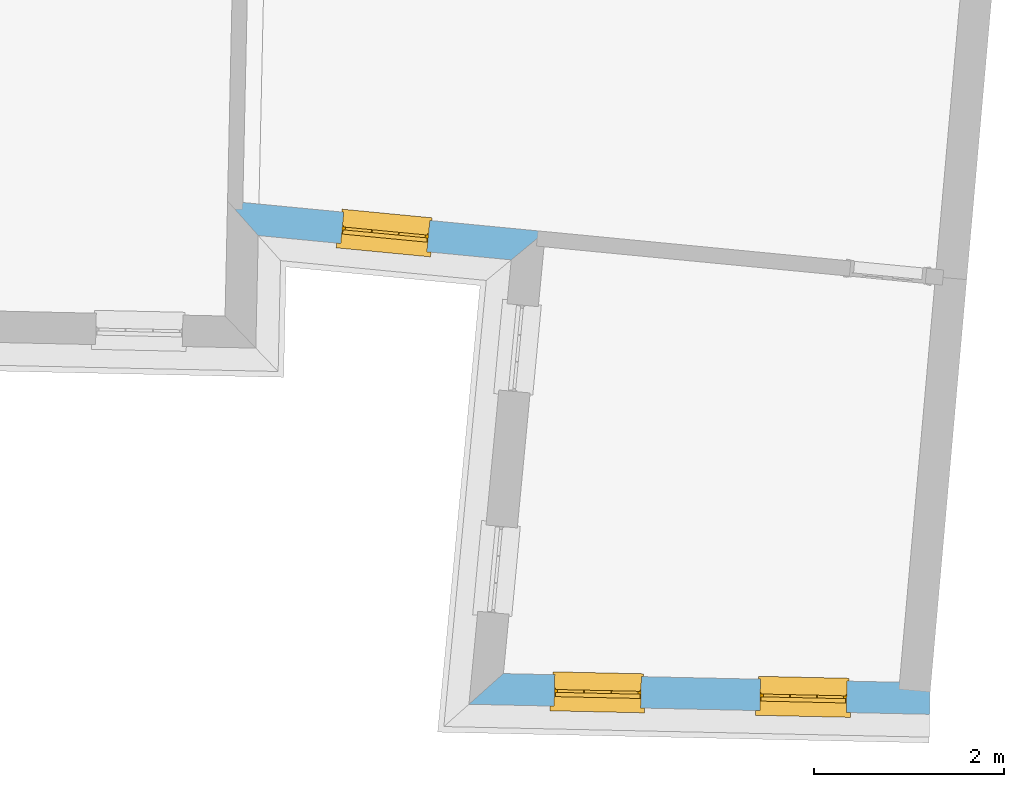
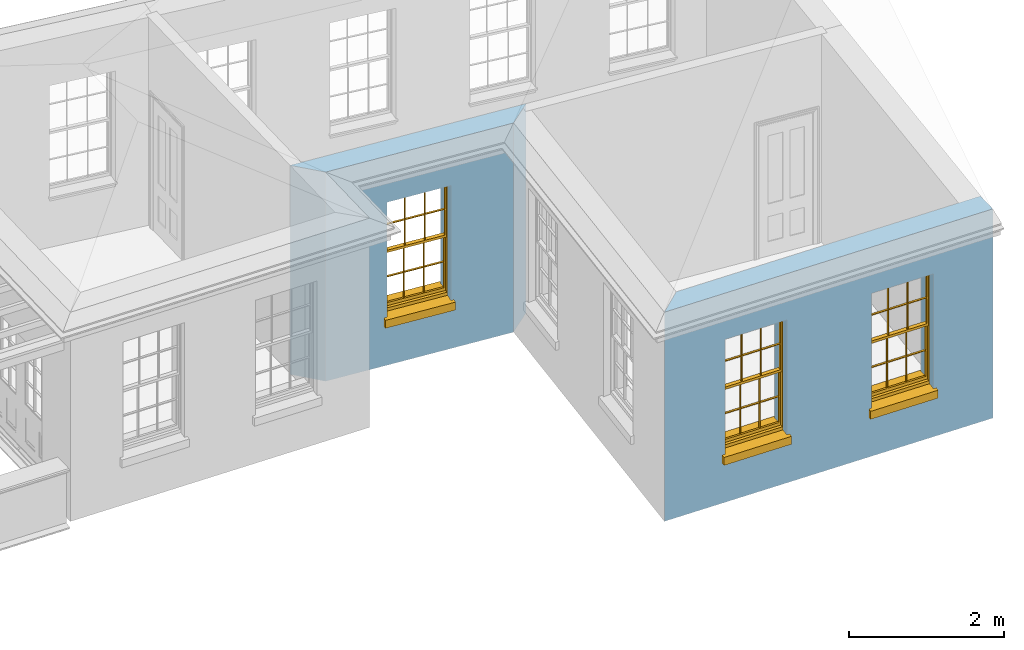
# One storey, part 6 of 12: 3 windows, 3 openings, plus 2 elements that do not belong to this part.
"""IFC2X3 building model written with IfcOpenShell, lengths in metres."""

from ifc_helpers import new_model, si_unit, frame, origin, place, context, subcontext, project, spatial, polyline, outline, extrude, faceted_brep, material, layer, layer_set, layer_usage, element, fill, save


model = new_model("IFC2X3")

# Units and contexts
model_context = context("Model", 3, world=origin())
body_context = subcontext(model_context, "Body", "Model", "MODEL_VIEW")
ifc_project = project(units=[si_unit("PLANEANGLEUNIT", "RADIAN"), si_unit("MASSUNIT", "GRAM", prefix="KILO"), si_unit("FORCEUNIT", "NEWTON", prefix="KILO"), si_unit("LENGTHUNIT", "METRE")], contexts=[model_context])

# Site, building, storey
site_placement = place(None, origin())
site = spatial("IfcSite", under=ifc_project, at=site_placement, CompositionType="ELEMENT")
building_placement = place(None, origin())
building = spatial("IfcBuilding", under=site, at=building_placement, Name="Building plot-18", CompositionType="ELEMENT")
storey_placement = place(None, frame((0.0, 0.0, 9.9)))
storey = spatial("IfcBuildingStorey", under=building, at=storey_placement, Name="Floor 2", CompositionType="ELEMENT", Elevation=9.9)

# Wall, opening, window
ifc_material = material(Name="Masonry")
ifc_layer = layer(ifc_material, 0.33, ventilated=False)
ifc_layer_set = layer_set([ifc_layer], Name="My Wall")
ifc_layer_usage = layer_usage(ifc_layer_set, "AXIS2", "NEGATIVE", 0.08)
wall_1_placement = place(storey_placement, origin())
wall_1 = element("IfcWallStandardCase", 1, at=wall_1_placement, inside=storey, material=ifc_layer_usage, Name="exterior", context=body_context, shape_type="SweptSolid", body=[
    extrude(outline(polyline([(93.8821736056846, 21.8550437590575), (94.2043231076959, 21.492511108805), (96.8612105097509, 21.2367803320634), (97.2209539104425, 21.533679413678), (93.8821736056846, 21.8550437590575)])), origin(), (0.0, 0.0, 1.0), 3.3),
])
opening_1_placement = place(storey_placement, frame((0.0, 0.0, 0.75)))
opening_1 = element("IfcOpeningElement", 2, at=opening_1_placement, cuts=wall_1, Name="Opening", ObjectType="Opening", context=body_context, shape_type="SweptSolid", body=[
    extrude(outline(polyline([(95.0701477438461, 21.4091737394635), (95.9759614837646, 21.3219873381452), (96.0075785303965, 21.65046924383), (95.101764790478, 21.7376556451482), (95.0701477438461, 21.4091737394635)])), origin(), (0.0, 0.0, 1.0), 1.82),
])
window_1_placement = place(storey_placement, frame((95.0941000519006, 21.6580236680125, 0.75), z_axis=(0.0, 0.0, 1.0), x_axis=(0.905813739918514, -0.0871864013182844, 0.0)))
window_1 = element("IfcWindow", 3, at=window_1_placement, inside=storey, Name="circulation outside window", OverallHeight=1.82, OverallWidth=0.91, context=body_context, shape_type="Brep", held_by="IfcProductRepresentation", body=[
    faceted_brep([(0.033125, -0.105, 0.975209), (0.01, -0.105, 0.975209), (0.033125, -0.105, 1.376042), (0.876875, -0.105, 0.975209), (0.876875, -0.105, 1.376042), (0.9, -0.105, 0.975209), (0.876875, -0.105, 1.386042), (0.876875, -0.105, 1.786875), (0.9, -0.105, 1.81), (0.033125, -0.105, 1.786875), (0.033125, -0.105, 1.386042), (0.01, -0.105, 1.81), (0.876875, -0.135, 1.376042), (0.876875, -0.135, 0.975209), (0.9, -0.135, 0.937083), (0.033125, -0.135, 1.786875), (0.01, -0.135, 1.81), (0.033125, -0.135, 1.386042), (0.01, -0.135, 0.937083), (0.033125, -0.135, 0.975209), (0.033125, -0.135, 1.376042), (0.876875, -0.135, 1.786875), (0.876875, -0.135, 1.386042), (0.9, -0.135, 1.81), (0.033125, -0.105, 0.937083), (0.01, -0.105, 0.937083), (0.033125, -0.105, 0.53625), (0.876875, -0.105, 0.937083), (0.876875, -0.105, 0.53625), (0.9, -0.105, 0.937083), (0.876875, -0.105, 0.52625), (0.876875, -0.105, 0.125417), (0.9, -0.105, 0.077167), (0.033125, -0.105, 0.125417), (0.033125, -0.105, 0.52625), (0.01, -0.105, 0.077167), (-0.0425, -0.25, 0.01), (-0.0425, -0.3, 0.001667), (0.0, -0.25, 0.01), (0.9525, -0.25, 0.01), (0.91, -0.25, 0.01), (0.9525, -0.3, 0.001667), (-0.02, 0.08, 0.077167), (0.0, 0.08, 0.077167), (-0.02, 0.11, 0.077167), (0.0, -0.06, 0.077167), (0.01, -0.06, 0.077167), (0.91, -0.06, 0.077167), (0.91, 0.08, 0.077167), (0.9, -0.06, 0.077167), (0.93, 0.08, 0.077167), (0.93, 0.11, 0.077167), (0.01, -0.075, 0.975209), (0.9, -0.075, 0.975209), (0.876875, -0.075, 0.125417), (0.876875, -0.075, 0.52625), (0.9, -0.075, 0.077167), (0.876875, -0.075, 0.53625), (0.876875, -0.075, 0.937083), (0.033125, -0.075, 0.125417), (0.01, -0.075, 0.077167), (0.033125, -0.075, 0.52625), (0.033125, -0.075, 0.937083), (0.033125, -0.075, 0.53625), (-0.02, 0.08, 0.052167), (-0.02, 0.11, 0.052167), (0.93, 0.11, 0.052167), (0.93, 0.08, 0.052167), (0.91, 0.08, 0.052167), (0.0, 0.08, 0.052167), (0.91, -0.15, 0.026667), (0.0, -0.15, 0.026667), (-0.0425, -0.3, -0.123333), (0.9525, -0.3, -0.123333), (-0.0425, -0.25, -0.123333), (0.9525, -0.25, -0.123333), (0.01, -0.06, 1.81), (0.9, -0.06, 1.81), (0.0, -0.06, 1.82), (0.91, -0.06, 1.82), (0.01, -0.15, 0.077167), (0.9, -0.15, 0.077167), (0.592292, -0.105, 0.125417), (0.592292, -0.075, 0.125417), (0.317708, -0.075, 0.125417), (0.317708, -0.105, 0.125417), (0.592292, -0.105, 0.53625), (0.317708, -0.105, 0.53625), (0.317708, -0.105, 0.52625), (0.592292, -0.105, 0.52625), (0.592292, -0.075, 0.53625), (0.317708, -0.075, 0.53625), (0.592292, -0.135, 1.386042), (0.592292, -0.105, 1.386042), (0.317708, -0.105, 1.386042), (0.317708, -0.135, 1.386042), (0.317708, -0.135, 1.376042), (0.592292, -0.135, 1.376042), (0.317708, -0.105, 1.376042), (0.592292, -0.105, 1.376042), (0.602292, -0.135, 1.376042), (0.592292, -0.135, 0.975209), (0.602292, -0.135, 0.975209), (0.602292, -0.105, 0.975209), (0.592292, -0.105, 0.975209), (0.602292, -0.105, 1.376042), (0.602292, -0.075, 0.53625), (0.602292, -0.105, 0.53625), (0.317708, -0.075, 0.52625), (0.307708, -0.075, 0.125417), (0.307708, -0.075, 0.52625), (0.602292, -0.075, 0.52625), (0.602292, -0.075, 0.125417), (0.592292, -0.075, 0.52625), (0.307708, -0.075, 0.53625), (0.317708, -0.075, 0.937083), (0.307708, -0.075, 0.937083), (0.602292, -0.075, 0.937083), (0.592292, -0.075, 0.937083), (0.307708, -0.105, 0.52625), (0.307708, -0.105, 0.125417), (0.307708, -0.105, 0.53625), (0.307708, -0.105, 0.937083), (0.592292, -0.105, 0.937083), (0.317708, -0.105, 0.937083), (0.602292, -0.105, 0.937083), (0.602292, -0.105, 0.52625), (0.602292, -0.105, 0.125417), (0.307708, -0.135, 1.386042), (0.307708, -0.135, 1.376042), (0.307708, -0.135, 0.975209), (0.317708, -0.135, 0.975209), (0.317708, -0.135, 1.786875), (0.307708, -0.135, 1.786875), (0.602292, -0.135, 1.786875), (0.592292, -0.135, 1.786875), (0.602292, -0.135, 1.386042), (0.602292, -0.105, 1.386042), (0.307708, -0.105, 1.386042), (0.307708, -0.105, 1.786875), (0.317708, -0.105, 1.786875), (0.592292, -0.105, 1.786875), (0.602292, -0.105, 1.786875), (0.307708, -0.105, 1.376042), (0.317708, -0.105, 0.975209), (0.307708, -0.105, 0.975209), (0.91, -0.15, 1.82), (0.9, -0.15, 1.81), (0.01, -0.15, 1.81), (0.0, -0.15, 1.82), (0.91, -0.25, 0.0), (0.0, -0.25, 0.0), (0.91, 0.08, 0.0), (0.0, 0.08, 0.0)], [[[0, 1, 2]], [[3, 4, 5]], [[6, 7, 8]], [[9, 10, 11]], [[12, 13, 14]], [[15, 16, 17]], [[18, 19, 20]], [[21, 22, 23]], [[24, 25, 26]], [[27, 28, 29]], [[30, 31, 32]], [[33, 34, 35]], [[14, 27, 29]], [[25, 24, 18]], [[36, 37, 38]], [[39, 40, 41]], [[42, 43, 44]], [[45, 46, 43]], [[47, 48, 49]], [[50, 51, 48]], [[1, 0, 52]], [[5, 53, 3]], [[54, 55, 56]], [[57, 58, 53]], [[59, 60, 61]], [[62, 63, 52]], [[48, 43, 46, 49]], [[51, 44, 43, 48]], [[64, 42, 44, 65]], [[65, 44, 51, 66]], [[66, 51, 50, 67]], [[65, 66, 68, 69]], [[60, 56, 49, 46]], [[70, 71, 38, 40]], [[37, 41, 40, 38]], [[37, 72, 73, 41]], [[74, 75, 73, 72]], [[8, 11, 76, 77]], [[76, 78, 79, 77]], [[32, 35, 80, 81]], [[81, 80, 71, 70]], [[82, 83, 84, 85]], [[86, 87, 88, 89]], [[86, 90, 91, 87]], [[92, 93, 94, 95]], [[92, 95, 96, 97]], [[96, 98, 99, 97]], [[100, 97, 101, 102]], [[103, 104, 99, 105]], [[97, 99, 104, 101]], [[102, 103, 105, 100]], [[28, 57, 106, 107]], [[108, 84, 109, 110]], [[111, 112, 83, 113]], [[114, 110, 61, 63]], [[90, 113, 108, 91]], [[115, 91, 114, 116]], [[117, 106, 90, 118]], [[111, 106, 57, 55]], [[119, 110, 109, 120]], [[34, 61, 110, 119]], [[89, 113, 83, 82]], [[88, 108, 113, 89]], [[85, 84, 108, 88]], [[121, 114, 63, 26]], [[122, 116, 114, 121]], [[123, 118, 90, 86]], [[87, 91, 115, 124]], [[107, 106, 117, 125]], [[126, 111, 55, 30]], [[127, 112, 111, 126]], [[126, 30, 28, 107]], [[88, 119, 120, 85]], [[126, 89, 82, 127]], [[125, 123, 86, 107]], [[121, 26, 34, 119]], [[124, 122, 121, 87]], [[128, 17, 20, 129]], [[96, 129, 130, 131]], [[132, 133, 128, 95]], [[134, 135, 92, 136]], [[100, 12, 22, 136]], [[137, 6, 4, 105]], [[94, 138, 139, 140]], [[137, 93, 141, 142]], [[99, 98, 94, 93]], [[143, 2, 10, 138]], [[144, 145, 143, 98]], [[129, 143, 145, 130]], [[20, 2, 143, 129]], [[131, 144, 98, 96]], [[128, 138, 10, 17]], [[133, 139, 138, 128]], [[135, 141, 93, 92]], [[95, 94, 140, 132]], [[22, 6, 137, 136]], [[136, 137, 142, 134]], [[100, 105, 4, 12]], [[107, 86, 89, 126]], [[106, 111, 113, 90]], [[91, 108, 110, 114]], [[87, 121, 119, 88]], [[97, 100, 136, 92]], [[129, 96, 95, 128]], [[98, 143, 138, 94]], [[105, 99, 93, 137]], [[131, 101, 104, 144]], [[124, 115, 118, 123]], [[132, 140, 141, 135]], [[120, 109, 59, 33]], [[15, 9, 139, 133]], [[134, 142, 7, 21]], [[31, 54, 112, 127]], [[36, 74, 72, 37]], [[39, 41, 73, 75]], [[18, 14, 101, 131]], [[23, 16, 132, 135]], [[83, 56, 60, 84]], [[52, 53, 118, 115]], [[53, 52, 144, 104]], [[11, 8, 141, 140]], [[14, 18, 124, 123]], [[2, 1, 11, 10]], [[8, 5, 4, 6]], [[57, 53, 56, 55]], [[60, 52, 63, 61]], [[26, 25, 35, 34]], [[32, 29, 28, 30]], [[14, 23, 22, 12]], [[18, 20, 17, 16]], [[19, 0, 2, 20]], [[17, 10, 9, 15]], [[12, 4, 3, 13]], [[21, 7, 6, 22]], [[27, 58, 57, 28]], [[30, 55, 54, 31]], [[33, 59, 61, 34]], [[26, 63, 62, 24]], [[5, 8, 77, 53]], [[76, 11, 1, 52]], [[46, 45, 78, 76]], [[49, 77, 79, 47]], [[70, 146, 147, 81]], [[71, 80, 148, 149]], [[19, 130, 145, 0]], [[102, 13, 3, 103]], [[116, 122, 24, 62]], [[29, 32, 81, 14]], [[80, 35, 25, 18]], [[60, 46, 76, 52]], [[77, 49, 56, 53]], [[23, 14, 81, 147]], [[16, 148, 80, 18]], [[35, 85, 120]], [[120, 33, 35]], [[127, 82, 32]], [[32, 31, 127]], [[32, 82, 85, 35]], [[102, 101, 14]], [[14, 13, 102]], [[18, 131, 130]], [[130, 19, 18]], [[134, 21, 23]], [[23, 135, 134]], [[16, 15, 133]], [[133, 132, 16]], [[11, 140, 139]], [[139, 9, 11]], [[142, 141, 8]], [[8, 7, 142]], [[23, 147, 148, 16]], [[146, 149, 148, 147]], [[52, 115, 116]], [[116, 62, 52]], [[118, 53, 117]], [[58, 117, 53]], [[27, 125, 117, 58]], [[56, 83, 112]], [[112, 54, 56]], [[109, 84, 60]], [[60, 59, 109]], [[125, 27, 14]], [[14, 123, 125]], [[122, 124, 18]], [[18, 24, 122]], [[145, 144, 52]], [[52, 0, 145]], [[103, 3, 53]], [[53, 104, 103]], [[79, 78, 149, 146]], [[78, 45, 71, 149]], [[146, 70, 47, 79]], [[150, 75, 74, 151]], [[68, 66, 67]], [[48, 68, 67, 50]], [[69, 64, 65]], [[42, 64, 69, 43]], [[69, 68, 152, 153]], [[70, 68, 48, 47]], [[150, 152, 68, 70]], [[43, 69, 71, 45]], [[69, 153, 151, 71]], [[152, 150, 151, 153]], [[38, 151, 74, 36]], [[71, 151, 38]], [[39, 75, 150, 40]], [[40, 150, 70]]]),
])
fill(opening_1, window_1)

# Wall, openings, windows
wall_2_placement = place(storey_placement, origin())
wall_2 = element("IfcWallStandardCase", 4, at=wall_2_placement, inside=storey, material=ifc_layer_usage, Name="exterior", context=body_context, shape_type="SweptSolid", body=[
    extrude(outline(polyline([(96.7792255874086, 16.8916819408247), (96.4170785766712, 16.5695240039888), (101.256865456868, 16.463666716343), (101.264081591148, 16.7935878090395), (96.7792255874086, 16.8916819408247)])), origin(), (0.0, 0.0, 1.0), 3.3),
])
opening_2_placement = place(storey_placement, frame((0.0, 0.0, 0.75)))
opening_2 = element("IfcOpeningElement", 5, at=opening_2_placement, cuts=wall_2, Name="Opening", ObjectType="Opening", context=body_context, shape_type="SweptSolid", body=[
    extrude(outline(polyline([(97.3113143084341, 16.5499650086398), (98.2210967155669, 16.5300659716882), (98.2283128498461, 16.8599870643847), (97.3185304427132, 16.8798861013363), (97.3113143084341, 16.5499650086398)])), origin(), (0.0, 0.0, 1.0), 1.82),
])
opening_3_placement = place(storey_placement, frame((0.0, 0.0, 0.75)))
opening_3 = element("IfcOpeningElement", 6, at=opening_3_placement, cuts=wall_2, Name="Opening", ObjectType="Opening", context=body_context, shape_type="SweptSolid", body=[
    extrude(outline(polyline([(99.4717941238529, 16.5027103383547), (100.381576530986, 16.482811301403), (100.388792665265, 16.8127323940996), (99.479010258132, 16.8326314310512), (99.4717941238529, 16.5027103383547)])), origin(), (0.0, 0.0, 1.0), 1.82),
])
window_2_placement = place(storey_placement, frame((97.3167810768274, 16.7999052303796, 0.75), z_axis=(0.0, 0.0, 1.0), x_axis=(0.909782407132838, -0.019899036951621, 0.0)))
window_2 = element("IfcWindow", 7, at=window_2_placement, inside=storey, Name="bedroom outside window", OverallHeight=1.82, OverallWidth=0.91, context=body_context, shape_type="Brep", held_by="IfcProductRepresentation", body=[
    faceted_brep([(0.033125, -0.105, 0.975209), (0.01, -0.105, 0.975209), (0.033125, -0.105, 1.376042), (0.876875, -0.105, 0.975209), (0.876875, -0.105, 1.376042), (0.9, -0.105, 0.975209), (0.876875, -0.105, 1.386042), (0.876875, -0.105, 1.786875), (0.9, -0.105, 1.81), (0.033125, -0.105, 1.786875), (0.033125, -0.105, 1.386042), (0.01, -0.105, 1.81), (0.876875, -0.135, 1.376042), (0.876875, -0.135, 0.975209), (0.9, -0.135, 0.937083), (0.033125, -0.135, 1.786875), (0.01, -0.135, 1.81), (0.033125, -0.135, 1.386042), (0.01, -0.135, 0.937083), (0.033125, -0.135, 0.975209), (0.033125, -0.135, 1.376042), (0.876875, -0.135, 1.786875), (0.876875, -0.135, 1.386042), (0.9, -0.135, 1.81), (0.033125, -0.105, 0.937083), (0.01, -0.105, 0.937083), (0.033125, -0.105, 0.53625), (0.876875, -0.105, 0.937083), (0.876875, -0.105, 0.53625), (0.9, -0.105, 0.937083), (0.876875, -0.105, 0.52625), (0.876875, -0.105, 0.125417), (0.9, -0.105, 0.077167), (0.033125, -0.105, 0.125417), (0.033125, -0.105, 0.52625), (0.01, -0.105, 0.077167), (-0.0425, -0.25, 0.01), (-0.0425, -0.3, 0.001667), (0.0, -0.25, 0.01), (0.9525, -0.25, 0.01), (0.91, -0.25, 0.01), (0.9525, -0.3, 0.001667), (-0.02, 0.08, 0.077167), (0.0, 0.08, 0.077167), (-0.02, 0.11, 0.077167), (0.0, -0.06, 0.077167), (0.01, -0.06, 0.077167), (0.91, -0.06, 0.077167), (0.91, 0.08, 0.077167), (0.9, -0.06, 0.077167), (0.93, 0.08, 0.077167), (0.93, 0.11, 0.077167), (0.01, -0.075, 0.975209), (0.9, -0.075, 0.975209), (0.876875, -0.075, 0.125417), (0.876875, -0.075, 0.52625), (0.9, -0.075, 0.077167), (0.876875, -0.075, 0.53625), (0.876875, -0.075, 0.937083), (0.033125, -0.075, 0.125417), (0.01, -0.075, 0.077167), (0.033125, -0.075, 0.52625), (0.033125, -0.075, 0.937083), (0.033125, -0.075, 0.53625), (-0.02, 0.08, 0.052167), (-0.02, 0.11, 0.052167), (0.93, 0.11, 0.052167), (0.93, 0.08, 0.052167), (0.91, 0.08, 0.052167), (0.0, 0.08, 0.052167), (0.91, -0.15, 0.026667), (0.0, -0.15, 0.026667), (-0.0425, -0.3, -0.123333), (0.9525, -0.3, -0.123333), (-0.0425, -0.25, -0.123333), (0.9525, -0.25, -0.123333), (0.01, -0.06, 1.81), (0.9, -0.06, 1.81), (0.0, -0.06, 1.82), (0.91, -0.06, 1.82), (0.01, -0.15, 0.077167), (0.9, -0.15, 0.077167), (0.592292, -0.105, 0.125417), (0.592292, -0.075, 0.125417), (0.317708, -0.075, 0.125417), (0.317708, -0.105, 0.125417), (0.592292, -0.105, 0.53625), (0.317708, -0.105, 0.53625), (0.317708, -0.105, 0.52625), (0.592292, -0.105, 0.52625), (0.592292, -0.075, 0.53625), (0.317708, -0.075, 0.53625), (0.592292, -0.135, 1.386042), (0.592292, -0.105, 1.386042), (0.317708, -0.105, 1.386042), (0.317708, -0.135, 1.386042), (0.317708, -0.135, 1.376042), (0.592292, -0.135, 1.376042), (0.317708, -0.105, 1.376042), (0.592292, -0.105, 1.376042), (0.602292, -0.135, 1.376042), (0.592292, -0.135, 0.975209), (0.602292, -0.135, 0.975209), (0.602292, -0.105, 0.975209), (0.592292, -0.105, 0.975209), (0.602292, -0.105, 1.376042), (0.602292, -0.075, 0.53625), (0.602292, -0.105, 0.53625), (0.317708, -0.075, 0.52625), (0.307708, -0.075, 0.125417), (0.307708, -0.075, 0.52625), (0.602292, -0.075, 0.52625), (0.602292, -0.075, 0.125417), (0.592292, -0.075, 0.52625), (0.307708, -0.075, 0.53625), (0.317708, -0.075, 0.937083), (0.307708, -0.075, 0.937083), (0.602292, -0.075, 0.937083), (0.592292, -0.075, 0.937083), (0.307708, -0.105, 0.52625), (0.307708, -0.105, 0.125417), (0.307708, -0.105, 0.53625), (0.307708, -0.105, 0.937083), (0.592292, -0.105, 0.937083), (0.317708, -0.105, 0.937083), (0.602292, -0.105, 0.937083), (0.602292, -0.105, 0.52625), (0.602292, -0.105, 0.125417), (0.307708, -0.135, 1.386042), (0.307708, -0.135, 1.376042), (0.307708, -0.135, 0.975209), (0.317708, -0.135, 0.975209), (0.317708, -0.135, 1.786875), (0.307708, -0.135, 1.786875), (0.602292, -0.135, 1.786875), (0.592292, -0.135, 1.786875), (0.602292, -0.135, 1.386042), (0.602292, -0.105, 1.386042), (0.307708, -0.105, 1.386042), (0.307708, -0.105, 1.786875), (0.317708, -0.105, 1.786875), (0.592292, -0.105, 1.786875), (0.602292, -0.105, 1.786875), (0.307708, -0.105, 1.376042), (0.317708, -0.105, 0.975209), (0.307708, -0.105, 0.975209), (0.91, -0.15, 1.82), (0.9, -0.15, 1.81), (0.01, -0.15, 1.81), (0.0, -0.15, 1.82), (0.91, -0.25, 0.0), (0.0, -0.25, 0.0), (0.91, 0.08, 0.0), (0.0, 0.08, 0.0)], [[[0, 1, 2]], [[3, 4, 5]], [[6, 7, 8]], [[9, 10, 11]], [[12, 13, 14]], [[15, 16, 17]], [[18, 19, 20]], [[21, 22, 23]], [[24, 25, 26]], [[27, 28, 29]], [[30, 31, 32]], [[33, 34, 35]], [[14, 27, 29]], [[25, 24, 18]], [[36, 37, 38]], [[39, 40, 41]], [[42, 43, 44]], [[45, 46, 43]], [[47, 48, 49]], [[50, 51, 48]], [[1, 0, 52]], [[5, 53, 3]], [[54, 55, 56]], [[57, 58, 53]], [[59, 60, 61]], [[62, 63, 52]], [[48, 43, 46, 49]], [[51, 44, 43, 48]], [[64, 42, 44, 65]], [[65, 44, 51, 66]], [[66, 51, 50, 67]], [[65, 66, 68, 69]], [[60, 56, 49, 46]], [[70, 71, 38, 40]], [[37, 41, 40, 38]], [[37, 72, 73, 41]], [[74, 75, 73, 72]], [[8, 11, 76, 77]], [[76, 78, 79, 77]], [[32, 35, 80, 81]], [[81, 80, 71, 70]], [[82, 83, 84, 85]], [[86, 87, 88, 89]], [[86, 90, 91, 87]], [[92, 93, 94, 95]], [[92, 95, 96, 97]], [[96, 98, 99, 97]], [[100, 97, 101, 102]], [[103, 104, 99, 105]], [[97, 99, 104, 101]], [[102, 103, 105, 100]], [[28, 57, 106, 107]], [[108, 84, 109, 110]], [[111, 112, 83, 113]], [[114, 110, 61, 63]], [[90, 113, 108, 91]], [[115, 91, 114, 116]], [[117, 106, 90, 118]], [[111, 106, 57, 55]], [[119, 110, 109, 120]], [[34, 61, 110, 119]], [[89, 113, 83, 82]], [[88, 108, 113, 89]], [[85, 84, 108, 88]], [[121, 114, 63, 26]], [[122, 116, 114, 121]], [[123, 118, 90, 86]], [[87, 91, 115, 124]], [[107, 106, 117, 125]], [[126, 111, 55, 30]], [[127, 112, 111, 126]], [[126, 30, 28, 107]], [[88, 119, 120, 85]], [[126, 89, 82, 127]], [[125, 123, 86, 107]], [[121, 26, 34, 119]], [[124, 122, 121, 87]], [[128, 17, 20, 129]], [[96, 129, 130, 131]], [[132, 133, 128, 95]], [[134, 135, 92, 136]], [[100, 12, 22, 136]], [[137, 6, 4, 105]], [[94, 138, 139, 140]], [[137, 93, 141, 142]], [[99, 98, 94, 93]], [[143, 2, 10, 138]], [[144, 145, 143, 98]], [[129, 143, 145, 130]], [[20, 2, 143, 129]], [[131, 144, 98, 96]], [[128, 138, 10, 17]], [[133, 139, 138, 128]], [[135, 141, 93, 92]], [[95, 94, 140, 132]], [[22, 6, 137, 136]], [[136, 137, 142, 134]], [[100, 105, 4, 12]], [[107, 86, 89, 126]], [[106, 111, 113, 90]], [[91, 108, 110, 114]], [[87, 121, 119, 88]], [[97, 100, 136, 92]], [[129, 96, 95, 128]], [[98, 143, 138, 94]], [[105, 99, 93, 137]], [[131, 101, 104, 144]], [[124, 115, 118, 123]], [[132, 140, 141, 135]], [[120, 109, 59, 33]], [[15, 9, 139, 133]], [[134, 142, 7, 21]], [[31, 54, 112, 127]], [[36, 74, 72, 37]], [[39, 41, 73, 75]], [[18, 14, 101, 131]], [[23, 16, 132, 135]], [[83, 56, 60, 84]], [[52, 53, 118, 115]], [[53, 52, 144, 104]], [[11, 8, 141, 140]], [[14, 18, 124, 123]], [[2, 1, 11, 10]], [[8, 5, 4, 6]], [[57, 53, 56, 55]], [[60, 52, 63, 61]], [[26, 25, 35, 34]], [[32, 29, 28, 30]], [[14, 23, 22, 12]], [[18, 20, 17, 16]], [[19, 0, 2, 20]], [[17, 10, 9, 15]], [[12, 4, 3, 13]], [[21, 7, 6, 22]], [[27, 58, 57, 28]], [[30, 55, 54, 31]], [[33, 59, 61, 34]], [[26, 63, 62, 24]], [[5, 8, 77, 53]], [[76, 11, 1, 52]], [[46, 45, 78, 76]], [[49, 77, 79, 47]], [[70, 146, 147, 81]], [[71, 80, 148, 149]], [[19, 130, 145, 0]], [[102, 13, 3, 103]], [[116, 122, 24, 62]], [[29, 32, 81, 14]], [[80, 35, 25, 18]], [[60, 46, 76, 52]], [[77, 49, 56, 53]], [[23, 14, 81, 147]], [[16, 148, 80, 18]], [[35, 85, 120]], [[120, 33, 35]], [[127, 82, 32]], [[32, 31, 127]], [[32, 82, 85, 35]], [[102, 101, 14]], [[14, 13, 102]], [[18, 131, 130]], [[130, 19, 18]], [[134, 21, 23]], [[23, 135, 134]], [[16, 15, 133]], [[133, 132, 16]], [[11, 140, 139]], [[139, 9, 11]], [[142, 141, 8]], [[8, 7, 142]], [[23, 147, 148, 16]], [[146, 149, 148, 147]], [[52, 115, 116]], [[116, 62, 52]], [[118, 53, 117]], [[58, 117, 53]], [[27, 125, 117, 58]], [[56, 83, 112]], [[112, 54, 56]], [[109, 84, 60]], [[60, 59, 109]], [[125, 27, 14]], [[14, 123, 125]], [[122, 124, 18]], [[18, 24, 122]], [[145, 144, 52]], [[52, 0, 145]], [[103, 3, 53]], [[53, 104, 103]], [[79, 78, 149, 146]], [[78, 45, 71, 149]], [[146, 70, 47, 79]], [[150, 75, 74, 151]], [[68, 66, 67]], [[48, 68, 67, 50]], [[69, 64, 65]], [[42, 64, 69, 43]], [[69, 68, 152, 153]], [[70, 68, 48, 47]], [[150, 152, 68, 70]], [[43, 69, 71, 45]], [[69, 153, 151, 71]], [[152, 150, 151, 153]], [[38, 151, 74, 36]], [[71, 151, 38]], [[39, 75, 150, 40]], [[40, 150, 70]]]),
])
fill(opening_2, window_2)
window_3_placement = place(storey_placement, frame((99.4772608922462, 16.7526505600945, 0.75), z_axis=(0.0, 0.0, 1.0), x_axis=(0.909782407132838, -0.019899036951621, 0.0)))
window_3 = element("IfcWindow", 8, at=window_3_placement, inside=storey, Name="bedroom outside window", OverallHeight=1.82, OverallWidth=0.91, context=body_context, shape_type="Brep", held_by="IfcProductRepresentation", body=[
    faceted_brep([(0.033125, -0.105, 0.975209), (0.01, -0.105, 0.975209), (0.033125, -0.105, 1.376042), (0.876875, -0.105, 0.975209), (0.876875, -0.105, 1.376042), (0.9, -0.105, 0.975209), (0.876875, -0.105, 1.386042), (0.876875, -0.105, 1.786875), (0.9, -0.105, 1.81), (0.033125, -0.105, 1.786875), (0.033125, -0.105, 1.386042), (0.01, -0.105, 1.81), (0.876875, -0.135, 1.376042), (0.876875, -0.135, 0.975209), (0.9, -0.135, 0.937083), (0.033125, -0.135, 1.786875), (0.01, -0.135, 1.81), (0.033125, -0.135, 1.386042), (0.01, -0.135, 0.937083), (0.033125, -0.135, 0.975209), (0.033125, -0.135, 1.376042), (0.876875, -0.135, 1.786875), (0.876875, -0.135, 1.386042), (0.9, -0.135, 1.81), (0.033125, -0.105, 0.937083), (0.01, -0.105, 0.937083), (0.033125, -0.105, 0.53625), (0.876875, -0.105, 0.937083), (0.876875, -0.105, 0.53625), (0.9, -0.105, 0.937083), (0.876875, -0.105, 0.52625), (0.876875, -0.105, 0.125417), (0.9, -0.105, 0.077167), (0.033125, -0.105, 0.125417), (0.033125, -0.105, 0.52625), (0.01, -0.105, 0.077167), (-0.0425, -0.25, 0.01), (-0.0425, -0.3, 0.001667), (0.0, -0.25, 0.01), (0.9525, -0.25, 0.01), (0.91, -0.25, 0.01), (0.9525, -0.3, 0.001667), (-0.02, 0.08, 0.077167), (0.0, 0.08, 0.077167), (-0.02, 0.11, 0.077167), (0.0, -0.06, 0.077167), (0.01, -0.06, 0.077167), (0.91, -0.06, 0.077167), (0.91, 0.08, 0.077167), (0.9, -0.06, 0.077167), (0.93, 0.08, 0.077167), (0.93, 0.11, 0.077167), (0.01, -0.075, 0.975209), (0.9, -0.075, 0.975209), (0.876875, -0.075, 0.125417), (0.876875, -0.075, 0.52625), (0.9, -0.075, 0.077167), (0.876875, -0.075, 0.53625), (0.876875, -0.075, 0.937083), (0.033125, -0.075, 0.125417), (0.01, -0.075, 0.077167), (0.033125, -0.075, 0.52625), (0.033125, -0.075, 0.937083), (0.033125, -0.075, 0.53625), (-0.02, 0.08, 0.052167), (-0.02, 0.11, 0.052167), (0.93, 0.11, 0.052167), (0.93, 0.08, 0.052167), (0.91, 0.08, 0.052167), (0.0, 0.08, 0.052167), (0.91, -0.15, 0.026667), (0.0, -0.15, 0.026667), (-0.0425, -0.3, -0.123333), (0.9525, -0.3, -0.123333), (-0.0425, -0.25, -0.123333), (0.9525, -0.25, -0.123333), (0.01, -0.06, 1.81), (0.9, -0.06, 1.81), (0.0, -0.06, 1.82), (0.91, -0.06, 1.82), (0.01, -0.15, 0.077167), (0.9, -0.15, 0.077167), (0.592292, -0.105, 0.125417), (0.592292, -0.075, 0.125417), (0.317708, -0.075, 0.125417), (0.317708, -0.105, 0.125417), (0.592292, -0.105, 0.53625), (0.317708, -0.105, 0.53625), (0.317708, -0.105, 0.52625), (0.592292, -0.105, 0.52625), (0.592292, -0.075, 0.53625), (0.317708, -0.075, 0.53625), (0.592292, -0.135, 1.386042), (0.592292, -0.105, 1.386042), (0.317708, -0.105, 1.386042), (0.317708, -0.135, 1.386042), (0.317708, -0.135, 1.376042), (0.592292, -0.135, 1.376042), (0.317708, -0.105, 1.376042), (0.592292, -0.105, 1.376042), (0.602292, -0.135, 1.376042), (0.592292, -0.135, 0.975209), (0.602292, -0.135, 0.975209), (0.602292, -0.105, 0.975209), (0.592292, -0.105, 0.975209), (0.602292, -0.105, 1.376042), (0.602292, -0.075, 0.53625), (0.602292, -0.105, 0.53625), (0.317708, -0.075, 0.52625), (0.307708, -0.075, 0.125417), (0.307708, -0.075, 0.52625), (0.602292, -0.075, 0.52625), (0.602292, -0.075, 0.125417), (0.592292, -0.075, 0.52625), (0.307708, -0.075, 0.53625), (0.317708, -0.075, 0.937083), (0.307708, -0.075, 0.937083), (0.602292, -0.075, 0.937083), (0.592292, -0.075, 0.937083), (0.307708, -0.105, 0.52625), (0.307708, -0.105, 0.125417), (0.307708, -0.105, 0.53625), (0.307708, -0.105, 0.937083), (0.592292, -0.105, 0.937083), (0.317708, -0.105, 0.937083), (0.602292, -0.105, 0.937083), (0.602292, -0.105, 0.52625), (0.602292, -0.105, 0.125417), (0.307708, -0.135, 1.386042), (0.307708, -0.135, 1.376042), (0.307708, -0.135, 0.975209), (0.317708, -0.135, 0.975209), (0.317708, -0.135, 1.786875), (0.307708, -0.135, 1.786875), (0.602292, -0.135, 1.786875), (0.592292, -0.135, 1.786875), (0.602292, -0.135, 1.386042), (0.602292, -0.105, 1.386042), (0.307708, -0.105, 1.386042), (0.307708, -0.105, 1.786875), (0.317708, -0.105, 1.786875), (0.592292, -0.105, 1.786875), (0.602292, -0.105, 1.786875), (0.307708, -0.105, 1.376042), (0.317708, -0.105, 0.975209), (0.307708, -0.105, 0.975209), (0.91, -0.15, 1.82), (0.9, -0.15, 1.81), (0.01, -0.15, 1.81), (0.0, -0.15, 1.82), (0.91, -0.25, 0.0), (0.0, -0.25, 0.0), (0.91, 0.08, 0.0), (0.0, 0.08, 0.0)], [[[0, 1, 2]], [[3, 4, 5]], [[6, 7, 8]], [[9, 10, 11]], [[12, 13, 14]], [[15, 16, 17]], [[18, 19, 20]], [[21, 22, 23]], [[24, 25, 26]], [[27, 28, 29]], [[30, 31, 32]], [[33, 34, 35]], [[14, 27, 29]], [[25, 24, 18]], [[36, 37, 38]], [[39, 40, 41]], [[42, 43, 44]], [[45, 46, 43]], [[47, 48, 49]], [[50, 51, 48]], [[1, 0, 52]], [[5, 53, 3]], [[54, 55, 56]], [[57, 58, 53]], [[59, 60, 61]], [[62, 63, 52]], [[48, 43, 46, 49]], [[51, 44, 43, 48]], [[64, 42, 44, 65]], [[65, 44, 51, 66]], [[66, 51, 50, 67]], [[65, 66, 68, 69]], [[60, 56, 49, 46]], [[70, 71, 38, 40]], [[37, 41, 40, 38]], [[37, 72, 73, 41]], [[74, 75, 73, 72]], [[8, 11, 76, 77]], [[76, 78, 79, 77]], [[32, 35, 80, 81]], [[81, 80, 71, 70]], [[82, 83, 84, 85]], [[86, 87, 88, 89]], [[86, 90, 91, 87]], [[92, 93, 94, 95]], [[92, 95, 96, 97]], [[96, 98, 99, 97]], [[100, 97, 101, 102]], [[103, 104, 99, 105]], [[97, 99, 104, 101]], [[102, 103, 105, 100]], [[28, 57, 106, 107]], [[108, 84, 109, 110]], [[111, 112, 83, 113]], [[114, 110, 61, 63]], [[90, 113, 108, 91]], [[115, 91, 114, 116]], [[117, 106, 90, 118]], [[111, 106, 57, 55]], [[119, 110, 109, 120]], [[34, 61, 110, 119]], [[89, 113, 83, 82]], [[88, 108, 113, 89]], [[85, 84, 108, 88]], [[121, 114, 63, 26]], [[122, 116, 114, 121]], [[123, 118, 90, 86]], [[87, 91, 115, 124]], [[107, 106, 117, 125]], [[126, 111, 55, 30]], [[127, 112, 111, 126]], [[126, 30, 28, 107]], [[88, 119, 120, 85]], [[126, 89, 82, 127]], [[125, 123, 86, 107]], [[121, 26, 34, 119]], [[124, 122, 121, 87]], [[128, 17, 20, 129]], [[96, 129, 130, 131]], [[132, 133, 128, 95]], [[134, 135, 92, 136]], [[100, 12, 22, 136]], [[137, 6, 4, 105]], [[94, 138, 139, 140]], [[137, 93, 141, 142]], [[99, 98, 94, 93]], [[143, 2, 10, 138]], [[144, 145, 143, 98]], [[129, 143, 145, 130]], [[20, 2, 143, 129]], [[131, 144, 98, 96]], [[128, 138, 10, 17]], [[133, 139, 138, 128]], [[135, 141, 93, 92]], [[95, 94, 140, 132]], [[22, 6, 137, 136]], [[136, 137, 142, 134]], [[100, 105, 4, 12]], [[107, 86, 89, 126]], [[106, 111, 113, 90]], [[91, 108, 110, 114]], [[87, 121, 119, 88]], [[97, 100, 136, 92]], [[129, 96, 95, 128]], [[98, 143, 138, 94]], [[105, 99, 93, 137]], [[131, 101, 104, 144]], [[124, 115, 118, 123]], [[132, 140, 141, 135]], [[120, 109, 59, 33]], [[15, 9, 139, 133]], [[134, 142, 7, 21]], [[31, 54, 112, 127]], [[36, 74, 72, 37]], [[39, 41, 73, 75]], [[18, 14, 101, 131]], [[23, 16, 132, 135]], [[83, 56, 60, 84]], [[52, 53, 118, 115]], [[53, 52, 144, 104]], [[11, 8, 141, 140]], [[14, 18, 124, 123]], [[2, 1, 11, 10]], [[8, 5, 4, 6]], [[57, 53, 56, 55]], [[60, 52, 63, 61]], [[26, 25, 35, 34]], [[32, 29, 28, 30]], [[14, 23, 22, 12]], [[18, 20, 17, 16]], [[19, 0, 2, 20]], [[17, 10, 9, 15]], [[12, 4, 3, 13]], [[21, 7, 6, 22]], [[27, 58, 57, 28]], [[30, 55, 54, 31]], [[33, 59, 61, 34]], [[26, 63, 62, 24]], [[5, 8, 77, 53]], [[76, 11, 1, 52]], [[46, 45, 78, 76]], [[49, 77, 79, 47]], [[70, 146, 147, 81]], [[71, 80, 148, 149]], [[19, 130, 145, 0]], [[102, 13, 3, 103]], [[116, 122, 24, 62]], [[29, 32, 81, 14]], [[80, 35, 25, 18]], [[60, 46, 76, 52]], [[77, 49, 56, 53]], [[23, 14, 81, 147]], [[16, 148, 80, 18]], [[35, 85, 120]], [[120, 33, 35]], [[127, 82, 32]], [[32, 31, 127]], [[32, 82, 85, 35]], [[102, 101, 14]], [[14, 13, 102]], [[18, 131, 130]], [[130, 19, 18]], [[134, 21, 23]], [[23, 135, 134]], [[16, 15, 133]], [[133, 132, 16]], [[11, 140, 139]], [[139, 9, 11]], [[142, 141, 8]], [[8, 7, 142]], [[23, 147, 148, 16]], [[146, 149, 148, 147]], [[52, 115, 116]], [[116, 62, 52]], [[118, 53, 117]], [[58, 117, 53]], [[27, 125, 117, 58]], [[56, 83, 112]], [[112, 54, 56]], [[109, 84, 60]], [[60, 59, 109]], [[125, 27, 14]], [[14, 123, 125]], [[122, 124, 18]], [[18, 24, 122]], [[145, 144, 52]], [[52, 0, 145]], [[103, 3, 53]], [[53, 104, 103]], [[79, 78, 149, 146]], [[78, 45, 71, 149]], [[146, 70, 47, 79]], [[150, 75, 74, 151]], [[68, 66, 67]], [[48, 68, 67, 50]], [[69, 64, 65]], [[42, 64, 69, 43]], [[69, 68, 152, 153]], [[70, 68, 48, 47]], [[150, 152, 68, 70]], [[43, 69, 71, 45]], [[69, 153, 151, 71]], [[152, 150, 151, 153]], [[38, 151, 74, 36]], [[71, 151, 38]], [[39, 75, 150, 40]], [[40, 150, 70]]]),
])
fill(opening_3, window_3)

save(model, "model.ifc")
